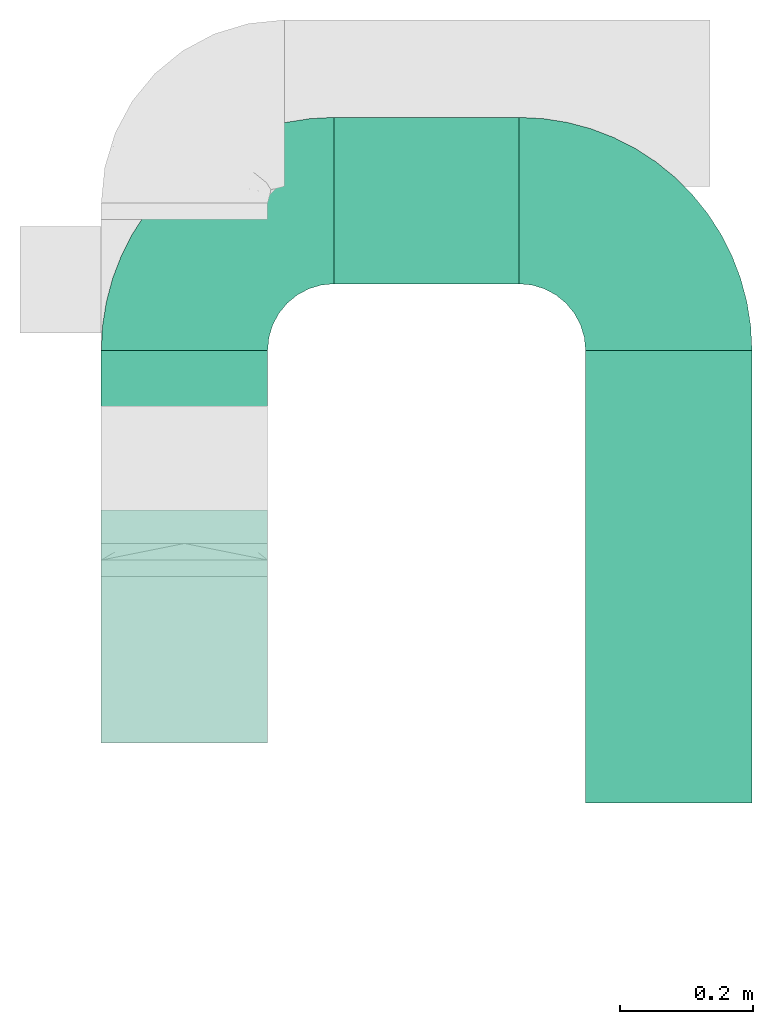
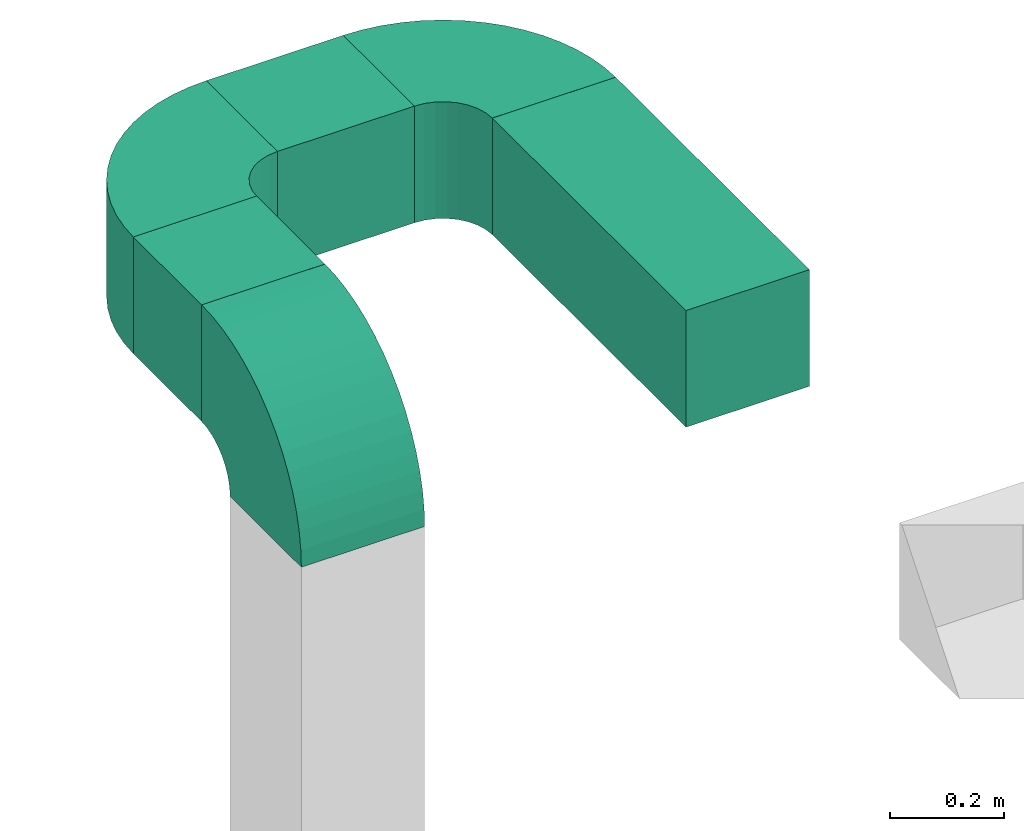
# One storey, part 4 of 5: 3 flow fittings, 3 flow segments.
"""IFC2X3 building model written with IfcOpenShell, lengths in millimetres."""

from ifc_helpers import new_model, entity, si_unit, converted_unit, derived_unit, direction, frame, frame_2d, origin, place, context, subcontext, project, spatial, polyline, circle_curve, parameter, trimmed, segment, composite_curve, rectangle, outline, extrude, source, transform, mapped, type_object, type_shapes, element, save


model = new_model("IFC2X3")

# Units and contexts
model_context = context("Model", 3, precision=0.01, world=origin(), true_north=direction((6.12303176911189e-17, 1.0)))
body_context = subcontext(model_context, "Body", "Model", "MODEL_VIEW")
ifc_project = project(units=[si_unit("LENGTHUNIT", "METRE", prefix="MILLI"), si_unit("AREAUNIT", "SQUARE_METRE"), si_unit("VOLUMEUNIT", "CUBIC_METRE"), converted_unit("PLANEANGLEUNIT", "DEGREE", entity("IfcRatioMeasure", 0.0174532925199433), si_unit("PLANEANGLEUNIT", "RADIAN"), dimensions=[0, 0, 0, 0, 0, 0, 0]), si_unit("MASSUNIT", "GRAM", prefix="KILO"), derived_unit("MASSDENSITYUNIT", [(si_unit("MASSUNIT", "GRAM", prefix="KILO"), 1), (si_unit("LENGTHUNIT", "METRE"), -3)]), si_unit("TIMEUNIT", "SECOND"), si_unit("FREQUENCYUNIT", "HERTZ"), si_unit("THERMODYNAMICTEMPERATUREUNIT", "DEGREE_CELSIUS"), derived_unit("THERMALTRANSMITTANCEUNIT", [(si_unit("MASSUNIT", "GRAM", prefix="KILO"), 1), (si_unit("THERMODYNAMICTEMPERATUREUNIT", "KELVIN"), -1), (si_unit("TIMEUNIT", "SECOND"), -3)]), derived_unit("VOLUMETRICFLOWRATEUNIT", [(si_unit("LENGTHUNIT", "METRE"), 3), (si_unit("TIMEUNIT", "SECOND"), -1)]), si_unit("ELECTRICCURRENTUNIT", "AMPERE"), si_unit("ELECTRICVOLTAGEUNIT", "VOLT"), si_unit("POWERUNIT", "WATT"), si_unit("FORCEUNIT", "NEWTON", prefix="KILO"), si_unit("ILLUMINANCEUNIT", "LUX"), si_unit("LUMINOUSFLUXUNIT", "LUMEN"), si_unit("LUMINOUSINTENSITYUNIT", "CANDELA"), derived_unit("USERDEFINED", [(si_unit("MASSUNIT", "GRAM", prefix="KILO"), -1), (si_unit("LENGTHUNIT", "METRE"), -2), (si_unit("TIMEUNIT", "SECOND"), 3), (si_unit("LUMINOUSFLUXUNIT", "LUMEN"), 1)]), derived_unit("LINEARVELOCITYUNIT", [(si_unit("LENGTHUNIT", "METRE"), 1), (si_unit("TIMEUNIT", "SECOND"), -1)]), si_unit("PRESSUREUNIT", "PASCAL"), derived_unit("USERDEFINED", [(si_unit("LENGTHUNIT", "METRE"), -2), (si_unit("MASSUNIT", "GRAM", prefix="KILO"), 1), (si_unit("TIMEUNIT", "SECOND"), -2)])], contexts=[model_context])

# Site, building, storey
site_placement = place(None, origin())
site = spatial("IfcSite", under=ifc_project, at=site_placement, CompositionType="ELEMENT")
building_placement = place(site_placement, origin())
building = spatial("IfcBuilding", under=site, at=building_placement, CompositionType="ELEMENT")
storey_placement = place(building_placement, frame((0.0, 0.0, 4000.0)))
storey = spatial("IfcBuildingStorey", under=building, at=storey_placement, Name="01 Level", CompositionType="ELEMENT", Elevation=4000.0)

# Flow segments
duct_segment_type = type_object("IfcDuctSegmentType", Name="Rectangular Duct:Air", PredefinedType="NOTDEFINED")
flow_segment_1_placement = place(storey_placement, frame((25070.9632723171, -68016.2395851399, 13110.9505263435)))
element("IfcFlowSegment", 1, at=flow_segment_1_placement, inside=storey, type_object=duct_segment_type, Name="Rectangular Duct:Air", ObjectType="Rectangular Duct:Air", context=body_context, shape_type="SweptSolid", body=[
    extrude(rectangle(XDim=239.999999999997, YDim=249.999999999999, at=frame_2d((0.0, -2.16715534406831e-12), x_axis=(1.0, 0.0))), frame((125.0, 120.0, 0.0), z_axis=(0.0, 0.0, 1.0), x_axis=(0.0, 1.0, 0.0)), (0.0, 0.0, 1.0), 249.999999999999),
])
flow_segment_2_placement = place(storey_placement, frame((25798.4900708518, -68456.2395851399, 13110.9505263435)))
element("IfcFlowSegment", 2, at=flow_segment_2_placement, inside=storey, type_object=duct_segment_type, Name="Rectangular Duct:Air", ObjectType="Rectangular Duct:Air", context=body_context, shape_type="SweptSolid", body=[
    extrude(rectangle(XDim=679.999999999993, YDim=249.999999999999, at=frame_2d((-4.34852154285181e-12, -2.16715534406831e-12), x_axis=(1.0, 0.0))), frame((125.0, 340.0, 0.0), z_axis=(0.0, 0.0, 1.0), x_axis=(0.0, 1.0, 0.0)), (0.0, 0.0, 1.0), 249.999999999999),
])
flow_segment_3_placement = place(storey_placement, frame((25420.9632723171, -67676.23958514, 13110.9505263435)))
element("IfcFlowSegment", 3, at=flow_segment_3_placement, inside=storey, type_object=duct_segment_type, Name="Rectangular Duct:Air", ObjectType="Rectangular Duct:Air", context=body_context, shape_type="SweptSolid", body=[
    extrude(rectangle(XDim=277.526798534734, YDim=250.000000000004, at=frame_2d((0.0, -4.33431068813661e-12), x_axis=(1.0, 0.0))), frame((138.763399267367, 125.0, 0.0)), (0.0, 0.0, 1.0), 249.999999999999),
])

# Flow fittings
duct_fitting_type = type_object("IfcDuctFittingType", Name="Air_Elbow_Rect", PredefinedType="NOTDEFINED")
shared_shape = source(origin(), body_context, "Body", "SweptSolid", [
    extrude(outline(composite_curve([segment(polyline([(-237.5, -112.5), (12.5, -112.5)]), True, "CONTINUOUS"), segment(trimmed(circle_curve(frame_2d((112.5, -112.5), x_axis=(0.0, 1.0)), 100.0), [parameter(0.0)], [parameter(90.0000000000001)], True, "PARAMETER"), False, "CONTINUOUS"), segment(polyline([(112.5, -12.4999999999998), (112.5, 237.5)]), True, "CONTINUOUS"), segment(trimmed(circle_curve(frame_2d((112.5, -112.5), x_axis=(0.0, 1.0)), 350.0), [parameter(0.0)], [parameter(90.0000000000001)], True, "PARAMETER"), True, "CONTINUOUS")], self_intersect=False)), frame((-112.499999999999, 112.5, -125.0), z_axis=(0.0, 0.0, 1.0), x_axis=(-1.0, 0.0, 0.0)), (0.0, 0.0, 1.0), 250.0),
])
type_shapes(duct_fitting_type, [shared_shape])
for number, where, z_axis, x_axis, name in (
    (4, (25195.9632723171, -68241.2395851399, 13235.9505263435), (-1.0, 0.0, 0.0), (0.0, 0.0, 1.0), "elbow1_001:Air_Elbow_Rect"),
    (5, (25195.9632723171, -67551.2395851399, 13235.9505263435), (0.0, 0.0, 1.0), (-1.0, 0.0, 0.0), "elbow1_001:Air_Elbow_Rect"),
    (6, (25923.4900708518, -67551.2395851399, 13235.9505263435), (0.0, 0.0, 1.0), (0.0, 1.0, 0.0), "elbow1_001:Air_Elbow_Rect"),
):
    element("IfcFlowFitting", number, at=place(storey_placement, frame(where, z_axis=z_axis, x_axis=x_axis)), inside=storey, type_object=duct_fitting_type, Name=name, ObjectType="elbow1_001:Air_Elbow_Rect", context=body_context, shape_type="MappedRepresentation", body=[
        mapped(shared_shape, transform((0.0, 0.0, 0.0), scale=1.0)),
    ])

save(model, "model.ifc")
